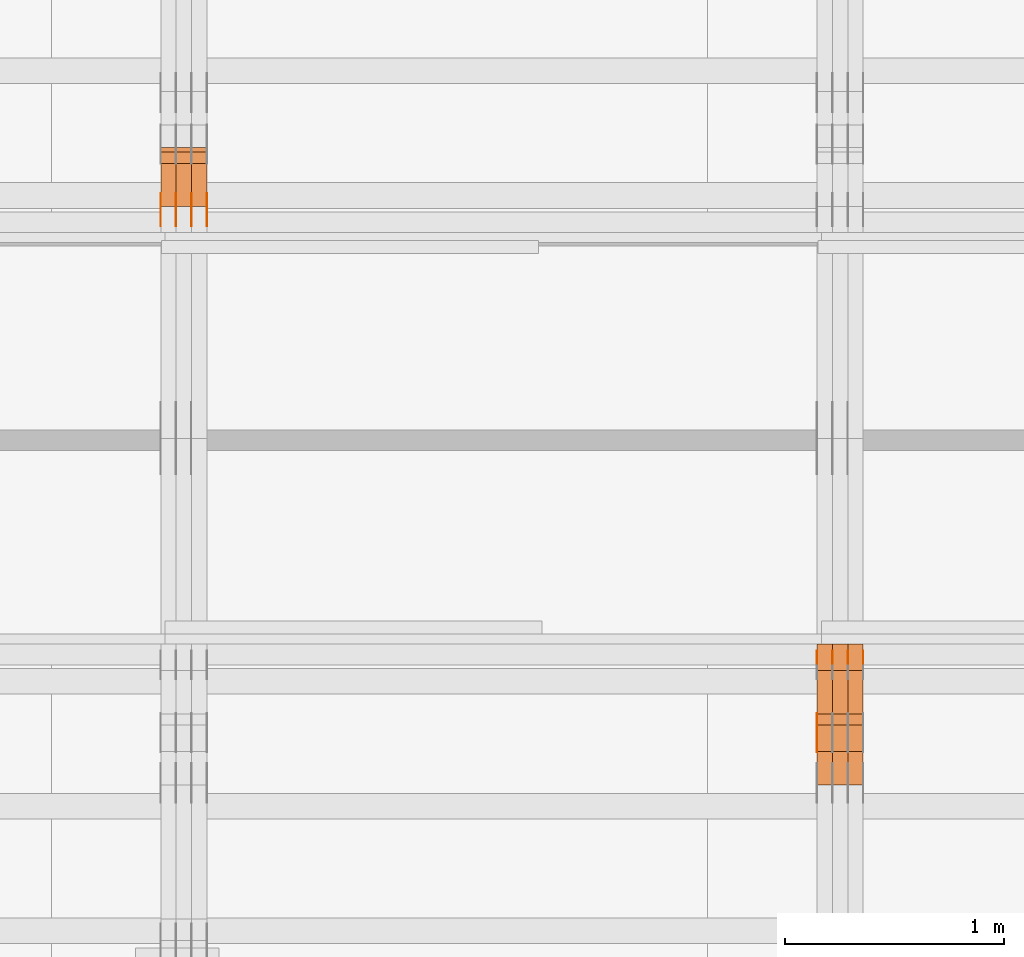
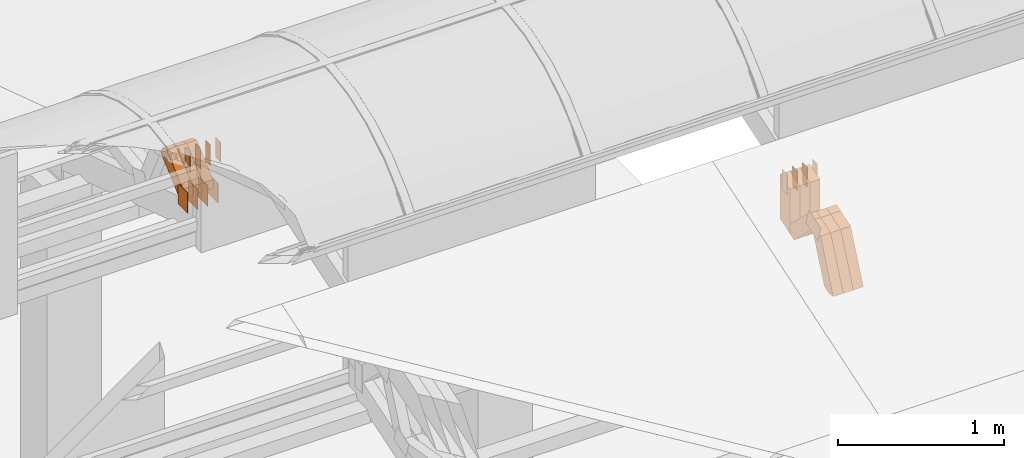
# One storey, part 299 of 385: 31 proxies.
"""IFC2X3 building model written with IfcOpenShell, lengths in millimetres."""

from ifc_helpers import new_model, entity, si_unit, converted_unit, derived_unit, direction, frame, origin, origin_2d_with_axis, place, context, subcontext, project, spatial, polyline, rectangle, outline, extrude, source, transform, mapped, material, type_object, type_shapes, element, save


model = new_model("IFC2X3")

# Units and contexts
model_context = context("Model", 3, precision=0.01, world=origin(), true_north=direction((6.12303176911189e-17, 1.0)))
body_context = subcontext(model_context, "Body", "Model", "MODEL_VIEW")
ifc_project = project(units=[si_unit("LENGTHUNIT", "METRE", prefix="MILLI"), si_unit("AREAUNIT", "SQUARE_METRE"), si_unit("VOLUMEUNIT", "CUBIC_METRE"), converted_unit("PLANEANGLEUNIT", "DEGREE", entity("IfcRatioMeasure", 0.0174532925199433), si_unit("PLANEANGLEUNIT", "RADIAN"), dimensions=[0, 0, 0, 0, 0, 0, 0]), si_unit("MASSUNIT", "GRAM", prefix="KILO"), derived_unit("MASSDENSITYUNIT", [(si_unit("MASSUNIT", "GRAM", prefix="KILO"), 1), (si_unit("LENGTHUNIT", "METRE"), -3)]), si_unit("TIMEUNIT", "SECOND"), si_unit("FREQUENCYUNIT", "HERTZ"), si_unit("THERMODYNAMICTEMPERATUREUNIT", "DEGREE_CELSIUS"), derived_unit("THERMALTRANSMITTANCEUNIT", [(si_unit("MASSUNIT", "GRAM", prefix="KILO"), 1), (si_unit("THERMODYNAMICTEMPERATUREUNIT", "KELVIN"), -1), (si_unit("TIMEUNIT", "SECOND"), -3)]), derived_unit("VOLUMETRICFLOWRATEUNIT", [(si_unit("LENGTHUNIT", "METRE"), 3), (si_unit("TIMEUNIT", "SECOND"), -1)]), si_unit("ELECTRICCURRENTUNIT", "AMPERE"), si_unit("ELECTRICVOLTAGEUNIT", "VOLT"), si_unit("POWERUNIT", "WATT"), si_unit("FORCEUNIT", "NEWTON", prefix="KILO"), si_unit("ILLUMINANCEUNIT", "LUX"), si_unit("LUMINOUSFLUXUNIT", "LUMEN"), si_unit("LUMINOUSINTENSITYUNIT", "CANDELA"), derived_unit("USERDEFINED", [(si_unit("MASSUNIT", "GRAM", prefix="KILO"), -1), (si_unit("LENGTHUNIT", "METRE"), -2), (si_unit("TIMEUNIT", "SECOND"), 3), (si_unit("LUMINOUSFLUXUNIT", "LUMEN"), 1)]), derived_unit("LINEARVELOCITYUNIT", [(si_unit("LENGTHUNIT", "METRE"), 1), (si_unit("TIMEUNIT", "SECOND"), -1)]), si_unit("PRESSUREUNIT", "PASCAL"), derived_unit("USERDEFINED", [(si_unit("LENGTHUNIT", "METRE"), -2), (si_unit("MASSUNIT", "GRAM", prefix="KILO"), 1), (si_unit("TIMEUNIT", "SECOND"), -2)])], contexts=[model_context])

# Site, building, storey
site_placement = place(None, origin())
site = spatial("IfcSite", under=ifc_project, at=site_placement, CompositionType="ELEMENT")
building_placement = place(site_placement, origin())
building = spatial("IfcBuilding", under=site, at=building_placement, CompositionType="ELEMENT")
storey_placement = place(building_placement, origin())
storey = spatial("IfcBuildingStorey", under=building, at=storey_placement, Name="Default", CompositionType="ELEMENT", Elevation=0.0)

# Proxies
ifc_material_1 = material(Name="IfcSurfaceStyle #544967")
building_element_proxy_type_1 = type_object("IfcBuildingElementProxyType", PredefinedType="NOTDEFINED", material=ifc_material_1)
shared_shape_1 = source(origin(), body_context, "Body", "SweptSolid", [
    extrude(outline(polyline([(-74.999875428623, -60.0000016373506), (74.9998605591059, -60.0000016373506), (74.9998754286239, 60.0000016373506), (-74.9998605591068, 60.0000016373506), (-74.999875428623, -60.0000016373506)])), frame((75.0002691827262, 60.0000190504561, 0.0), z_axis=(0.0, 0.0, 1.0), x_axis=(-1.0, 0.0, 0.0)), (0.0, 0.0, 1.0), 1.29999999999999),
])
type_shapes(building_element_proxy_type_1, [shared_shape_1])
proxy_1_placement = place(building_placement, frame((45175.0, 13285.0865109705, 3819.37496637467), z_axis=(-1.0, 0.0, 0.0), x_axis=(0.0, 0.951056516295154, 0.309016994374948)))
element("IfcBuildingElementProxy", 1, at=proxy_1_placement, inside=storey, type_object=building_element_proxy_type_1, material=ifc_material_1, context=body_context, shape_type="MappedRepresentation", body=[
    mapped(shared_shape_1, transform((0.0, 0.0, 0.0), scale=1.0)),
])
ifc_material_2 = material(Name="IfcSurfaceStyle #544568")
building_element_proxy_type_2 = type_object("IfcBuildingElementProxyType", PredefinedType="NOTDEFINED", material=ifc_material_2)
shared_shape_2 = source(origin(), body_context, "Body", "SweptSolid", [
    extrude(rectangle(XDim=150.0, YDim=60.0, at=origin_2d_with_axis()), frame((75.0000705696166, 30.0, 0.0), z_axis=(0.0, 0.0, 1.0), x_axis=(-1.0, 0.0, 0.0)), (0.0, 0.0, 1.0), 1.3),
])
type_shapes(building_element_proxy_type_2, [shared_shape_2])
proxy_2_placement = place(building_placement, frame((45386.3, 13750.0, 3972.59919166337), z_axis=(-1.0, 0.0, 0.0), x_axis=(0.0, 0.0, -1.0)))
element("IfcBuildingElementProxy", 2, at=proxy_2_placement, inside=storey, type_object=building_element_proxy_type_2, material=ifc_material_2, context=body_context, shape_type="MappedRepresentation", body=[
    mapped(shared_shape_2, transform((0.0, 0.0, 0.0), scale=1.0)),
])
ifc_material_3 = material(Name="IfcSurfaceStyle #544511")
building_element_proxy_type_3 = type_object("IfcBuildingElementProxyType", PredefinedType="NOTDEFINED", material=ifc_material_3)
shared_shape_3 = source(origin(), body_context, "Body", "SweptSolid", [
    extrude(rectangle(XDim=150.0, YDim=60.0, at=origin_2d_with_axis()), frame((75.0000705696166, 30.0, 0.0), z_axis=(0.0, 0.0, 1.0), x_axis=(-1.0, 0.0, 0.0)), (0.0, 0.0, 1.0), 1.3),
])
type_shapes(building_element_proxy_type_3, [shared_shape_3])
proxy_3_placement = place(building_placement, frame((45315.0, 13750.0, 3972.59919166337), z_axis=(-1.0, 0.0, 0.0), x_axis=(0.0, 0.0, -1.0)))
element("IfcBuildingElementProxy", 3, at=proxy_3_placement, inside=storey, type_object=building_element_proxy_type_3, material=ifc_material_3, context=body_context, shape_type="MappedRepresentation", body=[
    mapped(shared_shape_3, transform((0.0, 0.0, 0.0), scale=1.0)),
])
ifc_material_4 = material(Name="IfcSurfaceStyle #544454")
building_element_proxy_type_4 = type_object("IfcBuildingElementProxyType", PredefinedType="NOTDEFINED", material=ifc_material_4)
shared_shape_4 = source(origin(), body_context, "Body", "SweptSolid", [
    extrude(rectangle(XDim=150.0, YDim=60.0, at=origin_2d_with_axis()), frame((75.0000705696166, 30.0, 0.0), z_axis=(0.0, 0.0, 1.0), x_axis=(-1.0, 0.0, 0.0)), (0.0, 0.0, 1.0), 1.3),
])
type_shapes(building_element_proxy_type_4, [shared_shape_4])
proxy_4_placement = place(building_placement, frame((45316.3, 13750.0, 3972.59919166337), z_axis=(-1.0, 0.0, 0.0), x_axis=(0.0, 0.0, -1.0)))
element("IfcBuildingElementProxy", 4, at=proxy_4_placement, inside=storey, type_object=building_element_proxy_type_4, material=ifc_material_4, context=body_context, shape_type="MappedRepresentation", body=[
    mapped(shared_shape_4, transform((0.0, 0.0, 0.0), scale=1.0)),
])
ifc_material_5 = material(Name="IfcSurfaceStyle #544397")
building_element_proxy_type_5 = type_object("IfcBuildingElementProxyType", PredefinedType="NOTDEFINED", material=ifc_material_5)
shared_shape_5 = source(origin(), body_context, "Body", "SweptSolid", [
    extrude(rectangle(XDim=150.0, YDim=60.0, at=origin_2d_with_axis()), frame((75.0000705696166, 30.0, 0.0), z_axis=(0.0, 0.0, 1.0), x_axis=(-1.0, 0.0, 0.0)), (0.0, 0.0, 1.0), 1.29999999999999),
])
type_shapes(building_element_proxy_type_5, [shared_shape_5])
proxy_5_placement = place(building_placement, frame((45245.0, 13750.0, 3972.59919166337), z_axis=(-1.0, 0.0, 0.0), x_axis=(0.0, 0.0, -1.0)))
element("IfcBuildingElementProxy", 5, at=proxy_5_placement, inside=storey, type_object=building_element_proxy_type_5, material=ifc_material_5, context=body_context, shape_type="MappedRepresentation", body=[
    mapped(shared_shape_5, transform((0.0, 0.0, 0.0), scale=1.0)),
])
ifc_material_6 = material(Name="IfcSurfaceStyle #544340")
building_element_proxy_type_6 = type_object("IfcBuildingElementProxyType", PredefinedType="NOTDEFINED", material=ifc_material_6)
shared_shape_6 = source(origin(), body_context, "Body", "SweptSolid", [
    extrude(rectangle(XDim=150.0, YDim=60.0, at=origin_2d_with_axis()), frame((75.0000705696166, 30.0, 0.0), z_axis=(0.0, 0.0, 1.0), x_axis=(-1.0, 0.0, 0.0)), (0.0, 0.0, 1.0), 1.29999999999999),
])
type_shapes(building_element_proxy_type_6, [shared_shape_6])
proxy_6_placement = place(building_placement, frame((45246.3, 13750.0, 3972.59919166337), z_axis=(-1.0, 0.0, 0.0), x_axis=(0.0, 0.0, -1.0)))
element("IfcBuildingElementProxy", 6, at=proxy_6_placement, inside=storey, type_object=building_element_proxy_type_6, material=ifc_material_6, context=body_context, shape_type="MappedRepresentation", body=[
    mapped(shared_shape_6, transform((0.0, 0.0, 0.0), scale=1.0)),
])
ifc_material_7 = material(Name="IfcSurfaceStyle #544283")
building_element_proxy_type_7 = type_object("IfcBuildingElementProxyType", PredefinedType="NOTDEFINED", material=ifc_material_7)
shared_shape_7 = source(origin(), body_context, "Body", "SweptSolid", [
    extrude(rectangle(XDim=150.0, YDim=60.0, at=origin_2d_with_axis()), frame((75.0000705696166, 30.0, 0.0), z_axis=(0.0, 0.0, 1.0), x_axis=(-1.0, 0.0, 0.0)), (0.0, 0.0, 1.0), 1.29999999999999),
])
type_shapes(building_element_proxy_type_7, [shared_shape_7])
proxy_7_placement = place(building_placement, frame((45175.0, 13750.0, 3972.59919166337), z_axis=(-1.0, 0.0, 0.0), x_axis=(0.0, 0.0, -1.0)))
element("IfcBuildingElementProxy", 7, at=proxy_7_placement, inside=storey, type_object=building_element_proxy_type_7, material=ifc_material_7, context=body_context, shape_type="MappedRepresentation", body=[
    mapped(shared_shape_7, transform((0.0, 0.0, 0.0), scale=1.0)),
])
ifc_material_8 = material(Name="IfcSurfaceStyle #535082")
building_element_proxy_type_8 = type_object("IfcBuildingElementProxyType", Name="T1-W49 535080", PredefinedType="NOTDEFINED", material=ifc_material_8)
shared_shape_8 = source(origin(), body_context, "Body", "SweptSolid", [
    extrude(outline(polyline([(-155.175867306415, -47.4997478409253), (152.310664695054, -47.4997478409253), (170.496756790954, -6.14570120142345e-05), (145.70957993751, 47.4998092979374), (-133.37808995724, 47.4998092979373), (-179.963044159863, -6.14570120298391e-05), (-155.175867306415, -47.4997478409253)])), frame((170.496756790954, 47.5001152140455, 0.0), z_axis=(0.0, 0.0, 1.0), x_axis=(-1.0, 0.0, 0.0)), (0.0, 0.0, 1.0), 70.0),
])
type_shapes(building_element_proxy_type_8, [shared_shape_8])
proxy_8_placement = place(building_placement, frame((45385.0, 13443.048524104, 3830.71841973934), z_axis=(-1.0, 0.0, 0.0), x_axis=(0.0, 0.713950095632063, -0.700196587357413)))
element("IfcBuildingElementProxy", 8, at=proxy_8_placement, inside=storey, type_object=building_element_proxy_type_8, material=ifc_material_8, Name="T1-W49", context=body_context, shape_type="MappedRepresentation", body=[
    mapped(shared_shape_8, transform((0.0, 0.0, 0.0), scale=1.0)),
])
ifc_material_9 = material(Name="IfcSurfaceStyle #535007")
building_element_proxy_type_9 = type_object("IfcBuildingElementProxyType", Name="T1-W49 535005", PredefinedType="NOTDEFINED", material=ifc_material_9)
shared_shape_9 = source(origin(), body_context, "Body", "SweptSolid", [
    extrude(outline(polyline([(-155.175867306415, -47.4997478409253), (152.310664695054, -47.4997478409253), (170.496756790954, -6.14570120142345e-05), (145.70957993751, 47.4998092979374), (-133.37808995724, 47.4998092979373), (-179.963044159863, -6.14570120298391e-05), (-155.175867306415, -47.4997478409253)])), frame((170.496756790954, 47.5001152140455, 0.0), z_axis=(0.0, 0.0, 1.0), x_axis=(-1.0, 0.0, 0.0)), (0.0, 0.0, 1.0), 70.0),
])
type_shapes(building_element_proxy_type_9, [shared_shape_9])
proxy_9_placement = place(building_placement, frame((45315.0, 13443.048524104, 3830.71841973934), z_axis=(-1.0, 0.0, 0.0), x_axis=(0.0, 0.713950095632063, -0.700196587357413)))
element("IfcBuildingElementProxy", 9, at=proxy_9_placement, inside=storey, type_object=building_element_proxy_type_9, material=ifc_material_9, Name="T1-W49", context=body_context, shape_type="MappedRepresentation", body=[
    mapped(shared_shape_9, transform((0.0, 0.0, 0.0), scale=1.0)),
])
ifc_material_10 = material(Name="IfcSurfaceStyle #534932")
building_element_proxy_type_10 = type_object("IfcBuildingElementProxyType", Name="T1-W49 534930", PredefinedType="NOTDEFINED", material=ifc_material_10)
shared_shape_10 = source(origin(), body_context, "Body", "SweptSolid", [
    extrude(outline(polyline([(-155.175867306415, -47.4997478409253), (152.310664695054, -47.4997478409253), (170.496756790954, -6.14570120142345e-05), (145.70957993751, 47.4998092979374), (-133.37808995724, 47.4998092979373), (-179.963044159863, -6.14570120298391e-05), (-155.175867306415, -47.4997478409253)])), frame((170.496756790954, 47.5001152140455, 0.0), z_axis=(0.0, 0.0, 1.0), x_axis=(-1.0, 0.0, 0.0)), (0.0, 0.0, 1.0), 70.0),
])
type_shapes(building_element_proxy_type_10, [shared_shape_10])
proxy_10_placement = place(building_placement, frame((45245.0, 13443.048524104, 3830.71841973934), z_axis=(-1.0, 0.0, 0.0), x_axis=(0.0, 0.713950095632063, -0.700196587357413)))
element("IfcBuildingElementProxy", 10, at=proxy_10_placement, inside=storey, type_object=building_element_proxy_type_10, material=ifc_material_10, Name="T1-W49", context=body_context, shape_type="MappedRepresentation", body=[
    mapped(shared_shape_10, transform((0.0, 0.0, 0.0), scale=1.0)),
])
ifc_material_11 = material(Name="IfcSurfaceStyle #534632")
building_element_proxy_type_11 = type_object("IfcBuildingElementProxyType", Name="T1-W1 534630", PredefinedType="NOTDEFINED", material=ifc_material_11)
shared_shape_11 = source(origin(), body_context, "Body", "SweptSolid", [
    extrude(outline(polyline([(-182.839782714844, -60.0), (143.849426269531, -60.0), (182.839660644531, 60.0), (-143.849304199219, 60.0), (-182.839782714844, -60.0)])), frame((182.839674685549, 60.0, 0.0), z_axis=(0.0, 0.0, 1.0), x_axis=(-1.0, 0.0, 0.0)), (0.0, 0.0, 1.0), 70.0),
])
type_shapes(building_element_proxy_type_11, [shared_shape_11])
proxy_11_placement = place(building_placement, frame((45385.0, 13660.0, 3551.41502502148), z_axis=(-1.0, 0.0, 0.0), x_axis=(0.0, 0.0, 1.0)))
element("IfcBuildingElementProxy", 11, at=proxy_11_placement, inside=storey, type_object=building_element_proxy_type_11, material=ifc_material_11, Name="T1-W1", context=body_context, shape_type="MappedRepresentation", body=[
    mapped(shared_shape_11, transform((0.0, 0.0, 0.0), scale=1.0)),
])
ifc_material_12 = material(Name="IfcSurfaceStyle #534575")
building_element_proxy_type_12 = type_object("IfcBuildingElementProxyType", Name="T1-W1 534573", PredefinedType="NOTDEFINED", material=ifc_material_12)
shared_shape_12 = source(origin(), body_context, "Body", "SweptSolid", [
    extrude(outline(polyline([(-182.839782714844, -60.0), (143.849426269531, -60.0), (182.839660644531, 60.0), (-143.849304199219, 60.0), (-182.839782714844, -60.0)])), frame((182.839674685549, 60.0, 0.0), z_axis=(0.0, 0.0, 1.0), x_axis=(-1.0, 0.0, 0.0)), (0.0, 0.0, 1.0), 70.0),
])
type_shapes(building_element_proxy_type_12, [shared_shape_12])
proxy_12_placement = place(building_placement, frame((45315.0, 13660.0, 3551.41502502148), z_axis=(-1.0, 0.0, 0.0), x_axis=(0.0, 0.0, 1.0)))
element("IfcBuildingElementProxy", 12, at=proxy_12_placement, inside=storey, type_object=building_element_proxy_type_12, material=ifc_material_12, Name="T1-W1", context=body_context, shape_type="MappedRepresentation", body=[
    mapped(shared_shape_12, transform((0.0, 0.0, 0.0), scale=1.0)),
])
ifc_material_13 = material(Name="IfcSurfaceStyle #534518")
building_element_proxy_type_13 = type_object("IfcBuildingElementProxyType", Name="T1-W1 534516", PredefinedType="NOTDEFINED", material=ifc_material_13)
shared_shape_13 = source(origin(), body_context, "Body", "SweptSolid", [
    extrude(outline(polyline([(-182.839782714844, -60.0), (143.849426269531, -60.0), (182.839660644531, 60.0), (-143.849304199219, 60.0), (-182.839782714844, -60.0)])), frame((182.839674685549, 60.0, 0.0), z_axis=(0.0, 0.0, 1.0), x_axis=(-1.0, 0.0, 0.0)), (0.0, 0.0, 1.0), 70.0),
])
type_shapes(building_element_proxy_type_13, [shared_shape_13])
proxy_13_placement = place(building_placement, frame((45245.0, 13660.0, 3551.41502502148), z_axis=(-1.0, 0.0, 0.0), x_axis=(0.0, 0.0, 1.0)))
element("IfcBuildingElementProxy", 13, at=proxy_13_placement, inside=storey, type_object=building_element_proxy_type_13, material=ifc_material_13, Name="T1-W1", context=body_context, shape_type="MappedRepresentation", body=[
    mapped(shared_shape_13, transform((0.0, 0.0, 0.0), scale=1.0)),
])
ifc_material_14 = material(Name="IfcSurfaceStyle #534092")
building_element_proxy_type_14 = type_object("IfcBuildingElementProxyType", Name="T1-W42 534090", PredefinedType="NOTDEFINED", material=ifc_material_14)
shared_shape_14 = source(origin(), body_context, "Body", "SweptSolid", [
    extrude(outline(polyline([(-284.837590197601, -47.4997543607933), (129.95880168156, -47.4997543607933), (171.972324990451, 0.000162623346093338), (183.717007105413, 47.4996730491203), (-200.810543579822, 47.4996730491203), (-284.837590197601, -47.4997543607933)])), frame((183.717155718752, 47.4999821655365, 0.0), z_axis=(0.0, 0.0, 1.0), x_axis=(-1.0, 0.0, 0.0)), (0.0, 0.0, 1.0), 70.0),
])
type_shapes(building_element_proxy_type_14, [shared_shape_14])
proxy_14_placement = place(building_placement, frame((45385.0, 13135.8834463264, 3404.958483022), z_axis=(-1.0, 0.0, 0.0), x_axis=(0.0, 0.398630596470292, 0.917111578575769)))
element("IfcBuildingElementProxy", 14, at=proxy_14_placement, inside=storey, type_object=building_element_proxy_type_14, material=ifc_material_14, Name="T1-W42", context=body_context, shape_type="MappedRepresentation", body=[
    mapped(shared_shape_14, transform((0.0, 0.0, 0.0), scale=1.0)),
])
ifc_material_15 = material(Name="IfcSurfaceStyle #534026")
building_element_proxy_type_15 = type_object("IfcBuildingElementProxyType", Name="T1-W42 534024", PredefinedType="NOTDEFINED", material=ifc_material_15)
shared_shape_15 = source(origin(), body_context, "Body", "SweptSolid", [
    extrude(outline(polyline([(-284.837590197601, -47.4997543607933), (129.95880168156, -47.4997543607933), (171.972324990451, 0.000162623346093338), (183.717007105413, 47.4996730491203), (-200.810543579822, 47.4996730491203), (-284.837590197601, -47.4997543607933)])), frame((183.717155718752, 47.4999821655365, 0.0), z_axis=(0.0, 0.0, 1.0), x_axis=(-1.0, 0.0, 0.0)), (0.0, 0.0, 1.0), 70.0),
])
type_shapes(building_element_proxy_type_15, [shared_shape_15])
proxy_15_placement = place(building_placement, frame((45315.0, 13135.8834463264, 3404.958483022), z_axis=(-1.0, 0.0, 0.0), x_axis=(0.0, 0.398630596470292, 0.917111578575769)))
element("IfcBuildingElementProxy", 15, at=proxy_15_placement, inside=storey, type_object=building_element_proxy_type_15, material=ifc_material_15, Name="T1-W42", context=body_context, shape_type="MappedRepresentation", body=[
    mapped(shared_shape_15, transform((0.0, 0.0, 0.0), scale=1.0)),
])
ifc_material_16 = material(Name="IfcSurfaceStyle #533960")
building_element_proxy_type_16 = type_object("IfcBuildingElementProxyType", Name="T1-W42 533958", PredefinedType="NOTDEFINED", material=ifc_material_16)
shared_shape_16 = source(origin(), body_context, "Body", "SweptSolid", [
    extrude(outline(polyline([(-284.837590197601, -47.4997543607933), (129.95880168156, -47.4997543607933), (171.972324990451, 0.000162623346093338), (183.717007105413, 47.4996730491203), (-200.810543579822, 47.4996730491203), (-284.837590197601, -47.4997543607933)])), frame((183.717155718752, 47.4999821655365, 0.0), z_axis=(0.0, 0.0, 1.0), x_axis=(-1.0, 0.0, 0.0)), (0.0, 0.0, 1.0), 70.0),
])
type_shapes(building_element_proxy_type_16, [shared_shape_16])
proxy_16_placement = place(building_placement, frame((45245.0, 13135.8834463264, 3404.958483022), z_axis=(-1.0, 0.0, 0.0), x_axis=(0.0, 0.398630596470292, 0.917111578575769)))
element("IfcBuildingElementProxy", 16, at=proxy_16_placement, inside=storey, type_object=building_element_proxy_type_16, material=ifc_material_16, Name="T1-W42", context=body_context, shape_type="MappedRepresentation", body=[
    mapped(shared_shape_16, transform((0.0, 0.0, 0.0), scale=1.0)),
])
ifc_material_17 = material(Name="IfcSurfaceStyle #515266")
building_element_proxy_type_17 = type_object("IfcBuildingElementProxyType", PredefinedType="NOTDEFINED", material=ifc_material_17)
shared_shape_17 = source(origin(), body_context, "Body", "SweptSolid", [
    extrude(rectangle(XDim=150.0, YDim=120.0, at=origin_2d_with_axis()), frame((75.0, 60.0, 0.0), z_axis=(0.0, 0.0, 1.0), x_axis=(-1.0, 0.0, 0.0)), (0.0, 0.0, 1.0), 1.3),
])
type_shapes(building_element_proxy_type_17, [shared_shape_17])
proxy_17_placement = place(building_placement, frame((42386.3, 15840.0, 3652.70166015625), z_axis=(-1.0, 0.0, 0.0), x_axis=(0.0, 0.0, -1.0)))
element("IfcBuildingElementProxy", 17, at=proxy_17_placement, inside=storey, type_object=building_element_proxy_type_17, material=ifc_material_17, context=body_context, shape_type="MappedRepresentation", body=[
    mapped(shared_shape_17, transform((0.0, 0.0, 0.0), scale=1.0)),
])
ifc_material_18 = material(Name="IfcSurfaceStyle #515209")
building_element_proxy_type_18 = type_object("IfcBuildingElementProxyType", PredefinedType="NOTDEFINED", material=ifc_material_18)
shared_shape_18 = source(origin(), body_context, "Body", "SweptSolid", [
    extrude(rectangle(XDim=150.0, YDim=120.0, at=origin_2d_with_axis()), frame((75.0, 60.0, 0.0), z_axis=(0.0, 0.0, 1.0), x_axis=(-1.0, 0.0, 0.0)), (0.0, 0.0, 1.0), 1.3),
])
type_shapes(building_element_proxy_type_18, [shared_shape_18])
proxy_18_placement = place(building_placement, frame((42315.0, 15840.0, 3652.70166015625), z_axis=(-1.0, 0.0, 0.0), x_axis=(0.0, 0.0, -1.0)))
element("IfcBuildingElementProxy", 18, at=proxy_18_placement, inside=storey, type_object=building_element_proxy_type_18, material=ifc_material_18, context=body_context, shape_type="MappedRepresentation", body=[
    mapped(shared_shape_18, transform((0.0, 0.0, 0.0), scale=1.0)),
])
ifc_material_19 = material(Name="IfcSurfaceStyle #515152")
building_element_proxy_type_19 = type_object("IfcBuildingElementProxyType", PredefinedType="NOTDEFINED", material=ifc_material_19)
shared_shape_19 = source(origin(), body_context, "Body", "SweptSolid", [
    extrude(rectangle(XDim=150.0, YDim=120.0, at=origin_2d_with_axis()), frame((75.0, 60.0, 0.0), z_axis=(0.0, 0.0, 1.0), x_axis=(-1.0, 0.0, 0.0)), (0.0, 0.0, 1.0), 1.3),
])
type_shapes(building_element_proxy_type_19, [shared_shape_19])
proxy_19_placement = place(building_placement, frame((42316.3, 15840.0, 3652.70166015625), z_axis=(-1.0, 0.0, 0.0), x_axis=(0.0, 0.0, -1.0)))
element("IfcBuildingElementProxy", 19, at=proxy_19_placement, inside=storey, type_object=building_element_proxy_type_19, material=ifc_material_19, context=body_context, shape_type="MappedRepresentation", body=[
    mapped(shared_shape_19, transform((0.0, 0.0, 0.0), scale=1.0)),
])
ifc_material_20 = material(Name="IfcSurfaceStyle #515095")
building_element_proxy_type_20 = type_object("IfcBuildingElementProxyType", PredefinedType="NOTDEFINED", material=ifc_material_20)
shared_shape_20 = source(origin(), body_context, "Body", "SweptSolid", [
    extrude(rectangle(XDim=150.0, YDim=120.0, at=origin_2d_with_axis()), frame((75.0, 60.0, 0.0), z_axis=(0.0, 0.0, 1.0), x_axis=(-1.0, 0.0, 0.0)), (0.0, 0.0, 1.0), 1.29999999999999),
])
type_shapes(building_element_proxy_type_20, [shared_shape_20])
proxy_20_placement = place(building_placement, frame((42245.0, 15840.0, 3652.70166015625), z_axis=(-1.0, 0.0, 0.0), x_axis=(0.0, 0.0, -1.0)))
element("IfcBuildingElementProxy", 20, at=proxy_20_placement, inside=storey, type_object=building_element_proxy_type_20, material=ifc_material_20, context=body_context, shape_type="MappedRepresentation", body=[
    mapped(shared_shape_20, transform((0.0, 0.0, 0.0), scale=1.0)),
])
ifc_material_21 = material(Name="IfcSurfaceStyle #515038")
building_element_proxy_type_21 = type_object("IfcBuildingElementProxyType", PredefinedType="NOTDEFINED", material=ifc_material_21)
shared_shape_21 = source(origin(), body_context, "Body", "SweptSolid", [
    extrude(rectangle(XDim=150.0, YDim=120.0, at=origin_2d_with_axis()), frame((75.0, 60.0, 0.0), z_axis=(0.0, 0.0, 1.0), x_axis=(-1.0, 0.0, 0.0)), (0.0, 0.0, 1.0), 1.29999999999999),
])
type_shapes(building_element_proxy_type_21, [shared_shape_21])
proxy_21_placement = place(building_placement, frame((42246.3, 15840.0, 3652.70166015625), z_axis=(-1.0, 0.0, 0.0), x_axis=(0.0, 0.0, -1.0)))
element("IfcBuildingElementProxy", 21, at=proxy_21_placement, inside=storey, type_object=building_element_proxy_type_21, material=ifc_material_21, context=body_context, shape_type="MappedRepresentation", body=[
    mapped(shared_shape_21, transform((0.0, 0.0, 0.0), scale=1.0)),
])
ifc_material_22 = material(Name="IfcSurfaceStyle #514981")
building_element_proxy_type_22 = type_object("IfcBuildingElementProxyType", PredefinedType="NOTDEFINED", material=ifc_material_22)
shared_shape_22 = source(origin(), body_context, "Body", "SweptSolid", [
    extrude(rectangle(XDim=150.0, YDim=120.0, at=origin_2d_with_axis()), frame((75.0, 60.0, 0.0), z_axis=(0.0, 0.0, 1.0), x_axis=(-1.0, 0.0, 0.0)), (0.0, 0.0, 1.0), 1.29999999999999),
])
type_shapes(building_element_proxy_type_22, [shared_shape_22])
proxy_22_placement = place(building_placement, frame((42175.0, 15840.0, 3652.70166015625), z_axis=(-1.0, 0.0, 0.0), x_axis=(0.0, 0.0, -1.0)))
element("IfcBuildingElementProxy", 22, at=proxy_22_placement, inside=storey, type_object=building_element_proxy_type_22, material=ifc_material_22, context=body_context, shape_type="MappedRepresentation", body=[
    mapped(shared_shape_22, transform((0.0, 0.0, 0.0), scale=1.0)),
])
ifc_material_23 = material(Name="IfcSurfaceStyle #509794")
building_element_proxy_type_23 = type_object("IfcBuildingElementProxyType", PredefinedType="NOTDEFINED", material=ifc_material_23)
shared_shape_23 = source(origin(), body_context, "Body", "SweptSolid", [
    extrude(rectangle(XDim=150.0, YDim=60.0, at=origin_2d_with_axis()), frame((75.0000705696311, 30.0, 0.0), z_axis=(0.0, 0.0, 1.0), x_axis=(-1.0, 0.0, 0.0)), (0.0, 0.0, 1.0), 1.3),
])
type_shapes(building_element_proxy_type_23, [shared_shape_23])
proxy_23_placement = place(building_placement, frame((42386.3, 15750.0, 3972.59919166338), z_axis=(-1.0, 0.0, 0.0), x_axis=(0.0, 0.0, -1.0)))
element("IfcBuildingElementProxy", 23, at=proxy_23_placement, inside=storey, type_object=building_element_proxy_type_23, material=ifc_material_23, context=body_context, shape_type="MappedRepresentation", body=[
    mapped(shared_shape_23, transform((0.0, 0.0, 0.0), scale=1.0)),
])
ifc_material_24 = material(Name="IfcSurfaceStyle #509737")
building_element_proxy_type_24 = type_object("IfcBuildingElementProxyType", PredefinedType="NOTDEFINED", material=ifc_material_24)
shared_shape_24 = source(origin(), body_context, "Body", "SweptSolid", [
    extrude(rectangle(XDim=150.0, YDim=60.0, at=origin_2d_with_axis()), frame((75.0000705696311, 30.0, 0.0), z_axis=(0.0, 0.0, 1.0), x_axis=(-1.0, 0.0, 0.0)), (0.0, 0.0, 1.0), 1.3),
])
type_shapes(building_element_proxy_type_24, [shared_shape_24])
proxy_24_placement = place(building_placement, frame((42315.0, 15750.0, 3972.59919166338), z_axis=(-1.0, 0.0, 0.0), x_axis=(0.0, 0.0, -1.0)))
element("IfcBuildingElementProxy", 24, at=proxy_24_placement, inside=storey, type_object=building_element_proxy_type_24, material=ifc_material_24, context=body_context, shape_type="MappedRepresentation", body=[
    mapped(shared_shape_24, transform((0.0, 0.0, 0.0), scale=1.0)),
])
ifc_material_25 = material(Name="IfcSurfaceStyle #509680")
building_element_proxy_type_25 = type_object("IfcBuildingElementProxyType", PredefinedType="NOTDEFINED", material=ifc_material_25)
shared_shape_25 = source(origin(), body_context, "Body", "SweptSolid", [
    extrude(rectangle(XDim=150.0, YDim=60.0, at=origin_2d_with_axis()), frame((75.0000705696311, 30.0, 0.0), z_axis=(0.0, 0.0, 1.0), x_axis=(-1.0, 0.0, 0.0)), (0.0, 0.0, 1.0), 1.3),
])
type_shapes(building_element_proxy_type_25, [shared_shape_25])
proxy_25_placement = place(building_placement, frame((42316.3, 15750.0, 3972.59919166338), z_axis=(-1.0, 0.0, 0.0), x_axis=(0.0, 0.0, -1.0)))
element("IfcBuildingElementProxy", 25, at=proxy_25_placement, inside=storey, type_object=building_element_proxy_type_25, material=ifc_material_25, context=body_context, shape_type="MappedRepresentation", body=[
    mapped(shared_shape_25, transform((0.0, 0.0, 0.0), scale=1.0)),
])
ifc_material_26 = material(Name="IfcSurfaceStyle #509623")
building_element_proxy_type_26 = type_object("IfcBuildingElementProxyType", PredefinedType="NOTDEFINED", material=ifc_material_26)
shared_shape_26 = source(origin(), body_context, "Body", "SweptSolid", [
    extrude(rectangle(XDim=150.0, YDim=60.0, at=origin_2d_with_axis()), frame((75.0000705696311, 30.0, 0.0), z_axis=(0.0, 0.0, 1.0), x_axis=(-1.0, 0.0, 0.0)), (0.0, 0.0, 1.0), 1.29999999999999),
])
type_shapes(building_element_proxy_type_26, [shared_shape_26])
proxy_26_placement = place(building_placement, frame((42245.0, 15750.0, 3972.59919166338), z_axis=(-1.0, 0.0, 0.0), x_axis=(0.0, 0.0, -1.0)))
element("IfcBuildingElementProxy", 26, at=proxy_26_placement, inside=storey, type_object=building_element_proxy_type_26, material=ifc_material_26, context=body_context, shape_type="MappedRepresentation", body=[
    mapped(shared_shape_26, transform((0.0, 0.0, 0.0), scale=1.0)),
])
ifc_material_27 = material(Name="IfcSurfaceStyle #509566")
building_element_proxy_type_27 = type_object("IfcBuildingElementProxyType", PredefinedType="NOTDEFINED", material=ifc_material_27)
shared_shape_27 = source(origin(), body_context, "Body", "SweptSolid", [
    extrude(rectangle(XDim=150.0, YDim=60.0, at=origin_2d_with_axis()), frame((75.0000705696311, 30.0, 0.0), z_axis=(0.0, 0.0, 1.0), x_axis=(-1.0, 0.0, 0.0)), (0.0, 0.0, 1.0), 1.29999999999999),
])
type_shapes(building_element_proxy_type_27, [shared_shape_27])
proxy_27_placement = place(building_placement, frame((42246.3, 15750.0, 3972.59919166338), z_axis=(-1.0, 0.0, 0.0), x_axis=(0.0, 0.0, -1.0)))
element("IfcBuildingElementProxy", 27, at=proxy_27_placement, inside=storey, type_object=building_element_proxy_type_27, material=ifc_material_27, context=body_context, shape_type="MappedRepresentation", body=[
    mapped(shared_shape_27, transform((0.0, 0.0, 0.0), scale=1.0)),
])
ifc_material_28 = material(Name="IfcSurfaceStyle #509509")
building_element_proxy_type_28 = type_object("IfcBuildingElementProxyType", PredefinedType="NOTDEFINED", material=ifc_material_28)
shared_shape_28 = source(origin(), body_context, "Body", "SweptSolid", [
    extrude(rectangle(XDim=150.0, YDim=60.0, at=origin_2d_with_axis()), frame((75.0000705696311, 30.0, 0.0), z_axis=(0.0, 0.0, 1.0), x_axis=(-1.0, 0.0, 0.0)), (0.0, 0.0, 1.0), 1.29999999999999),
])
type_shapes(building_element_proxy_type_28, [shared_shape_28])
proxy_28_placement = place(building_placement, frame((42175.0, 15750.0, 3972.59919166338), z_axis=(-1.0, 0.0, 0.0), x_axis=(0.0, 0.0, -1.0)))
element("IfcBuildingElementProxy", 28, at=proxy_28_placement, inside=storey, type_object=building_element_proxy_type_28, material=ifc_material_28, context=body_context, shape_type="MappedRepresentation", body=[
    mapped(shared_shape_28, transform((0.0, 0.0, 0.0), scale=1.0)),
])
ifc_material_29 = material(Name="IfcSurfaceStyle #500425")
building_element_proxy_type_29 = type_object("IfcBuildingElementProxyType", Name="T1-W50 500423", PredefinedType="NOTDEFINED", material=ifc_material_29)
shared_shape_29 = source(origin(), body_context, "Body", "SweptSolid", [
    extrude(outline(polyline([(-128.56619634284, -47.4999385885712), (133.151257249084, -47.4999385885712), (161.172800006526, -0.000129729183733609), (147.291467726413, 47.500068317755), (-142.513973767368, 47.500068317755), (-170.535354871815, -0.000129729183754689), (-128.56619634284, -47.4999385885712)])), frame((161.17310141218, 47.5001898716564, 0.0), z_axis=(0.0, 0.0, 1.0), x_axis=(-1.0, 0.0, 0.0)), (0.0, 0.0, 1.0), 70.0),
])
type_shapes(building_element_proxy_type_29, [shared_shape_29])
proxy_29_placement = place(building_placement, frame((42385.0, 16060.0297689714, 3761.73994820667), z_axis=(-1.0, 0.0, 0.0), x_axis=(0.0, -0.749388407538668, -0.662130662820156)))
element("IfcBuildingElementProxy", 29, at=proxy_29_placement, inside=storey, type_object=building_element_proxy_type_29, material=ifc_material_29, Name="T1-W50", context=body_context, shape_type="MappedRepresentation", body=[
    mapped(shared_shape_29, transform((0.0, 0.0, 0.0), scale=1.0)),
])
ifc_material_30 = material(Name="IfcSurfaceStyle #500350")
building_element_proxy_type_30 = type_object("IfcBuildingElementProxyType", Name="T1-W50 500348", PredefinedType="NOTDEFINED", material=ifc_material_30)
shared_shape_30 = source(origin(), body_context, "Body", "SweptSolid", [
    extrude(outline(polyline([(-128.56619634284, -47.4999385885712), (133.151257249084, -47.4999385885712), (161.172800006526, -0.000129729183733609), (147.291467726413, 47.500068317755), (-142.513973767368, 47.500068317755), (-170.535354871815, -0.000129729183754689), (-128.56619634284, -47.4999385885712)])), frame((161.17310141218, 47.5001898716564, 0.0), z_axis=(0.0, 0.0, 1.0), x_axis=(-1.0, 0.0, 0.0)), (0.0, 0.0, 1.0), 70.0),
])
type_shapes(building_element_proxy_type_30, [shared_shape_30])
proxy_30_placement = place(building_placement, frame((42315.0, 16060.0297689714, 3761.73994820667), z_axis=(-1.0, 0.0, 0.0), x_axis=(0.0, -0.749388407538668, -0.662130662820156)))
element("IfcBuildingElementProxy", 30, at=proxy_30_placement, inside=storey, type_object=building_element_proxy_type_30, material=ifc_material_30, Name="T1-W50", context=body_context, shape_type="MappedRepresentation", body=[
    mapped(shared_shape_30, transform((0.0, 0.0, 0.0), scale=1.0)),
])
ifc_material_31 = material(Name="IfcSurfaceStyle #500275")
building_element_proxy_type_31 = type_object("IfcBuildingElementProxyType", Name="T1-W50 500273", PredefinedType="NOTDEFINED", material=ifc_material_31)
shared_shape_31 = source(origin(), body_context, "Body", "SweptSolid", [
    extrude(outline(polyline([(-128.56619634284, -47.4999385885712), (133.151257249084, -47.4999385885712), (161.172800006526, -0.000129729183733609), (147.291467726413, 47.500068317755), (-142.513973767368, 47.500068317755), (-170.535354871815, -0.000129729183754689), (-128.56619634284, -47.4999385885712)])), frame((161.17310141218, 47.5001898716564, 0.0), z_axis=(0.0, 0.0, 1.0), x_axis=(-1.0, 0.0, 0.0)), (0.0, 0.0, 1.0), 70.0),
])
type_shapes(building_element_proxy_type_31, [shared_shape_31])
proxy_31_placement = place(building_placement, frame((42245.0, 16060.0297689714, 3761.73994820667), z_axis=(-1.0, 0.0, 0.0), x_axis=(0.0, -0.749388407538668, -0.662130662820156)))
element("IfcBuildingElementProxy", 31, at=proxy_31_placement, inside=storey, type_object=building_element_proxy_type_31, material=ifc_material_31, Name="T1-W50", context=body_context, shape_type="MappedRepresentation", body=[
    mapped(shared_shape_31, transform((0.0, 0.0, 0.0), scale=1.0)),
])

save(model, "model.ifc")
